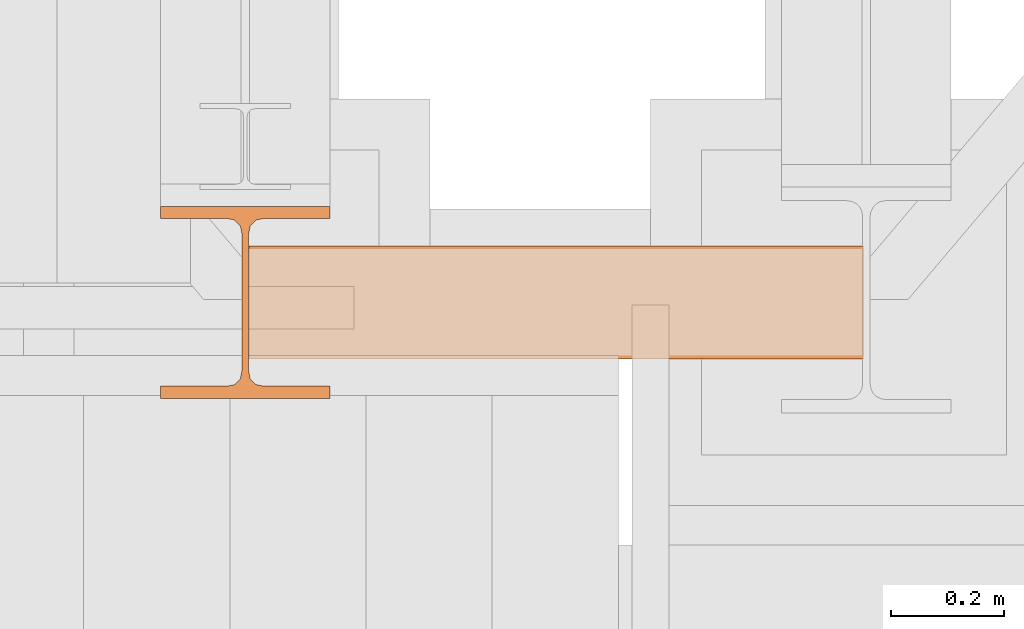
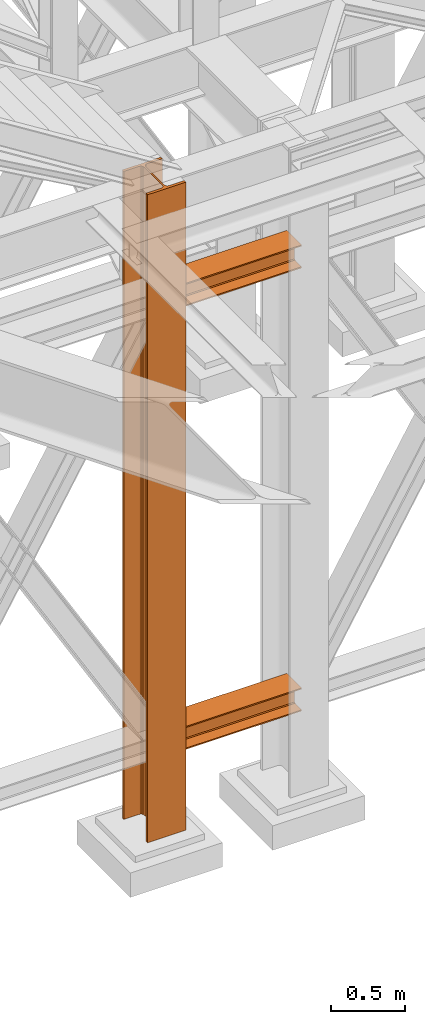
# One storey, part 22 of 208: 3 proxies.
"""IFC2X3 building model written with IfcOpenShell, lengths in millimetres."""

from ifc_helpers import new_model, entity, si_unit, converted_unit, frame, origin, origin_with_axes, place, context, subcontext, project, spatial, faceted_brep, material, element, save


model = new_model("IFC2X3")

# Units and contexts
model_context = context("Model", 3, precision=1e-05, world=origin())
plan_context = context("Plan", 3, precision=1e-05, world=origin())
body_context = subcontext(model_context, "Body", "Model", "MODEL_VIEW")
ifc_project = project(units=[si_unit("LENGTHUNIT", "METRE", prefix="MILLI"), converted_unit("PLANEANGLEUNIT", "DEGREE", entity("IfcPlaneAngleMeasure", 0.0174532925199433), si_unit("PLANEANGLEUNIT", "RADIAN"), dimensions=[0, 0, 0, 0, 0, 0, 0]), si_unit("AREAUNIT", "SQUARE_METRE"), si_unit("VOLUMEUNIT", "CUBIC_METRE")], contexts=[model_context, plan_context])

# Building, storey
building_placement = place(None, origin())
building = spatial("IfcBuilding", under=ifc_project, at=building_placement, CompositionType="COMPLEX")
storey_placement = place(building_placement, origin_with_axes())
storey = spatial("IfcBuildingStorey", under=building, at=storey_placement, Name="Geschoss", CompositionType="ELEMENT")

# Proxies
ifc_material = material(Name="35/80cm")
proxy_1_placement = place(storey_placement, frame((-1256.745037431798, -17432.57439531565, -65.01000000000022), z_axis=(0.0, 0.0, 1.0), x_axis=(1.0, 0.0, 0.0)))
element("IfcBuildingElementProxy", 1, at=proxy_1_placement, inside=storey, material=ifc_material, context=body_context, shape_type="Brep", body=[
    faceted_brep([(300.010011920929, 0.00999999999839929, 0.01000000000027512), (300.010011920929, 21.51000631809075, 0.01000000000027512), (183.0100057816505, 21.51000631809075, 0.01000000000027512), (169.0362909978628, 24.30682016372521, 0.01000000000027512), (158.8068282401562, 34.5362885093673, 0.01000000000027512), (156.0100060126185, 48.51000143050987, 0.01000000000027512), (156.0100060126185, 291.509994695185, 0.01000000000027512), (158.8068282401562, 305.4837150669082, 0.01000000000027512), (169.0362909978628, 315.7131685113891, 0.01000000000027512), (183.0100057816505, 318.5099972581847, 0.01000000000027512), (300.010011920929, 318.5099972581847, 0.01000000000027512), (300.010011920929, 340.0100035762771, 0.01000000000027512), (0.009999999999990905, 340.0100035762771, 0.01000000000027512), (0.009999999999990905, 318.5099972581847, 0.01000000000027512), (117.0100061392784, 318.5099972581847, 0.01000000000027512), (130.9837209230661, 315.7131685113891, 0.01000000000027512), (141.2131836807728, 305.4837150669082, 0.01000000000027512), (144.0100059083104, 291.509994695185, 0.01000000000027512), (144.0100059083104, 48.51000143050987, 0.01000000000027512), (141.2131836807728, 34.5362885093673, 0.01000000000027512), (130.9837209230661, 24.30682016372521, 0.01000000000027512), (117.0100061392784, 21.51000631809075, 0.01000000000027512), (0.009999999999990905, 21.51000631809075, 0.01000000000027512), (0.009999999999990905, 0.00999999999839929, 0.01000000000027512), (300.010011920929, 21.51000631809075, 5350.010005364416), (300.010011920929, 0.00999999999839929, 5350.010005364416), (0.009999999999990905, 0.00999999999839929, 5350.010005364416), (0.009999999999990905, 21.51000631809075, 5350.010005364416), (117.0100061392784, 21.51000631809075, 5350.010005364416), (130.9837209230661, 24.30682016372521, 5350.010005364416), (141.2131836807728, 34.5362885093673, 5350.010005364416), (144.0100059083104, 48.51000143050987, 5350.010005364416), (144.0100059083104, 291.509994695185, 5350.010005364416), (141.2131836807728, 305.4837150669082, 5350.010005364416), (130.9837209230661, 315.7131685113891, 5350.010005364416), (117.0100061392784, 318.5099972581847, 5350.010005364416), (0.009999999999990905, 318.5099972581847, 5350.010005364416), (0.009999999999990905, 340.0100035762771, 5350.010005364416), (300.010011920929, 340.0100035762771, 5350.010005364416), (300.010011920929, 318.5099972581847, 5350.010005364416), (183.0100057816505, 318.5099972581847, 5350.010005364416), (169.0362909978628, 315.7131685113891, 5350.010005364416), (158.8068282401562, 305.4837150669082, 5350.010005364416), (156.0100060126185, 291.509994695185, 5350.010005364416), (156.0100060126185, 48.51000143050987, 5350.010005364416), (158.8068282401562, 34.5362885093673, 5350.010005364416), (169.0362909978628, 24.30682016372521, 5350.010005364416), (183.0100057816505, 21.51000631809075, 5350.010005364416), (300.010011920929, 21.51000631809075, 0.01000000000027512), (300.010011920929, 0.00999999999839929, 0.01000000000027512), (300.010011920929, 0.00999999999839929, 5350.010005364416), (300.010011920929, 21.51000631809075, 5350.010005364416), (183.0100057816505, 21.51000631809075, 0.01000000000027512), (300.010011920929, 21.51000631809075, 0.01000000000027512), (300.010011920929, 21.51000631809075, 5350.010005364416), (183.0100057816505, 21.51000631809075, 5350.010005364416), (169.0362909978628, 24.30682016372521, 0.01000000000027512), (183.0100057816505, 21.51000631809075, 0.01000000000027512), (183.0100057816505, 21.51000631809075, 5350.010005364416), (169.0362909978628, 24.30682016372521, 5350.010005364416), (158.8068282401562, 34.5362885093673, 0.01000000000027512), (169.0362909978628, 24.30682016372521, 0.01000000000027512), (169.0362909978628, 24.30682016372521, 5350.010005364416), (158.8068282401562, 34.5362885093673, 5350.010005364416), (156.0100060126185, 48.51000143050987, 0.01000000000027512), (158.8068282401562, 34.5362885093673, 0.01000000000027512), (158.8068282401562, 34.5362885093673, 5350.010005364416), (156.0100060126185, 48.51000143050987, 5350.010005364416), (156.0100060126185, 291.509994695185, 0.01000000000027512), (156.0100060126185, 48.51000143050987, 0.01000000000027512), (156.0100060126185, 48.51000143050987, 5350.010005364416), (156.0100060126185, 291.509994695185, 5350.010005364416), (158.8068282401562, 305.4837150669082, 0.01000000000027512), (156.0100060126185, 291.509994695185, 0.01000000000027512), (156.0100060126185, 291.509994695185, 5350.010005364416), (158.8068282401562, 305.4837150669082, 5350.010005364416), (169.0362909978628, 315.7131685113891, 0.01000000000027512), (158.8068282401562, 305.4837150669082, 0.01000000000027512), (158.8068282401562, 305.4837150669082, 5350.010005364416), (169.0362909978628, 315.7131685113891, 5350.010005364416), (183.0100057816505, 318.5099972581847, 0.01000000000027512), (169.0362909978628, 315.7131685113891, 0.01000000000027512), (169.0362909978628, 315.7131685113891, 5350.010005364416), (183.0100057816505, 318.5099972581847, 5350.010005364416), (300.010011920929, 318.5099972581847, 0.01000000000027512), (183.0100057816505, 318.5099972581847, 0.01000000000027512), (183.0100057816505, 318.5099972581847, 5350.010005364416), (300.010011920929, 318.5099972581847, 5350.010005364416), (300.010011920929, 340.0100035762771, 0.01000000000027512), (300.010011920929, 318.5099972581847, 0.01000000000027512), (300.010011920929, 318.5099972581847, 5350.010005364416), (300.010011920929, 340.0100035762771, 5350.010005364416), (0.009999999999990905, 340.0100035762771, 0.01000000000027512), (300.010011920929, 340.0100035762771, 0.01000000000027512), (300.010011920929, 340.0100035762771, 5350.010005364416), (0.009999999999990905, 340.0100035762771, 5350.010005364416), (0.009999999999990905, 318.5099972581847, 0.01000000000027512), (0.009999999999990905, 340.0100035762771, 0.01000000000027512), (0.009999999999990905, 340.0100035762771, 5350.010005364416), (0.009999999999990905, 318.5099972581847, 5350.010005364416), (117.0100061392784, 318.5099972581847, 0.01000000000027512), (0.009999999999990905, 318.5099972581847, 0.01000000000027512), (0.009999999999990905, 318.5099972581847, 5350.010005364416), (117.0100061392784, 318.5099972581847, 5350.010005364416), (130.9837209230661, 315.7131685113891, 0.01000000000027512), (117.0100061392784, 318.5099972581847, 0.01000000000027512), (117.0100061392784, 318.5099972581847, 5350.010005364416), (130.9837209230661, 315.7131685113891, 5350.010005364416), (141.2131836807728, 305.4837150669082, 0.01000000000027512), (130.9837209230661, 315.7131685113891, 0.01000000000027512), (130.9837209230661, 315.7131685113891, 5350.010005364416), (141.2131836807728, 305.4837150669082, 5350.010005364416), (144.0100059083104, 291.509994695185, 0.01000000000027512), (141.2131836807728, 305.4837150669082, 0.01000000000027512), (141.2131836807728, 305.4837150669082, 5350.010005364416), (144.0100059083104, 291.509994695185, 5350.010005364416), (144.0100059083104, 48.51000143050987, 0.01000000000027512), (144.0100059083104, 291.509994695185, 0.01000000000027512), (144.0100059083104, 291.509994695185, 5350.010005364416), (144.0100059083104, 48.51000143050987, 5350.010005364416), (141.2131836807728, 34.5362885093673, 0.01000000000027512), (144.0100059083104, 48.51000143050987, 0.01000000000027512), (144.0100059083104, 48.51000143050987, 5350.010005364416), (141.2131836807728, 34.5362885093673, 5350.010005364416), (130.9837209230661, 24.30682016372521, 0.01000000000027512), (141.2131836807728, 34.5362885093673, 0.01000000000027512), (141.2131836807728, 34.5362885093673, 5350.010005364416), (130.9837209230661, 24.30682016372521, 5350.010005364416), (117.0100061392784, 21.51000631809075, 0.01000000000027512), (130.9837209230661, 24.30682016372521, 0.01000000000027512), (130.9837209230661, 24.30682016372521, 5350.010005364416), (117.0100061392784, 21.51000631809075, 5350.010005364416), (0.009999999999990905, 21.51000631809075, 0.01000000000027512), (117.0100061392784, 21.51000631809075, 0.01000000000027512), (117.0100061392784, 21.51000631809075, 5350.010005364416), (0.009999999999990905, 21.51000631809075, 5350.010005364416), (0.009999999999990905, 0.00999999999839929, 0.01000000000027512), (0.009999999999990905, 21.51000631809075, 0.01000000000027512), (0.009999999999990905, 21.51000631809075, 5350.010005364416), (0.009999999999990905, 0.00999999999839929, 5350.010005364416), (300.010011920929, 0.00999999999839929, 0.01000000000027512), (0.009999999999990905, 0.00999999999839929, 0.01000000000027512), (0.009999999999990905, 0.00999999999839929, 5350.010005364416), (300.010011920929, 0.00999999999839929, 5350.010005364416)], [[[0, 1, 2, 3, 4, 5, 6, 7, 8, 9, 10, 11, 12, 13, 14, 15, 16, 17, 18, 19, 20, 21, 22, 23]], [[24, 25, 26, 27, 28, 29, 30, 31, 32, 33, 34, 35, 36, 37, 38, 39, 40, 41, 42, 43, 44, 45, 46, 47]], [[48, 49, 50, 51]], [[52, 53, 54, 55]], [[56, 57, 58, 59]], [[60, 61, 62, 63]], [[64, 65, 66, 67]], [[68, 69, 70, 71]], [[72, 73, 74, 75]], [[76, 77, 78, 79]], [[80, 81, 82, 83]], [[84, 85, 86, 87]], [[88, 89, 90, 91]], [[92, 93, 94, 95]], [[96, 97, 98, 99]], [[100, 101, 102, 103]], [[104, 105, 106, 107]], [[108, 109, 110, 111]], [[112, 113, 114, 115]], [[116, 117, 118, 119]], [[120, 121, 122, 123]], [[124, 125, 126, 127]], [[128, 129, 130, 131]], [[132, 133, 134, 135]], [[136, 137, 138, 139]], [[140, 141, 142, 143]]], orient=[[False], [False], [False], [False], [False], [False], [False], [False], [False], [False], [False], [False], [False], [False], [False], [False], [False], [False], [False], [False], [False], [False], [False], [False], [False], [False]]),
])
proxy_2_placement = place(storey_placement, frame((-1099.995025406557, -17362.5323246858, 544.9900024165573), z_axis=(0.0, 0.0, 1.0), x_axis=(1.0, 0.0, 0.0)))
element("IfcBuildingElementProxy", 2, at=proxy_2_placement, inside=storey, context=body_context, shape_type="Brep", body=[
    faceted_brep([(1088.009999895692, 0.00999999999839929, 190.0100125169756), (1088.009999895692, 200.0100029802306, 190.0100125169756), (1088.009999895692, 200.0100029802306, 180.0100146031382), (1088.009999895692, 121.2600035762771, 180.0100071525576), (1088.009999895692, 111.9441915473326, 178.1454621052744), (1088.009999895692, 105.1245498640819, 171.3258190250399), (1088.009999895692, 103.2600015571697, 162.010007927418), (1088.009999895692, 103.2600015571697, 28.00999713897727), (1088.009999895692, 105.1245498640819, 18.69418604135535), (1088.009999895692, 111.9441915473326, 11.87454296112082), (1088.009999895692, 121.2600035762771, 10.00999791383765), (1088.009999895692, 200.0100029802306, 10.00999791383765), (1088.009999895692, 200.0100029802306, 0.01000000000021828), (1088.009999895692, 0.00999999999839929, 0.01000000000021828), (1088.009999895692, 0.00999999999839929, 10.00999791383765), (1088.009999895692, 78.75999940395195, 10.00999791383765), (1088.009999895692, 88.07581143289644, 11.87454296112082), (1088.009999895692, 94.89545311614711, 18.69418604135535), (1088.009999895692, 96.7600014230593, 28.00999713897727), (1088.009999895692, 96.7600014230593, 162.010007927418), (1088.009999895692, 94.89545311614711, 171.3258190250399), (1088.009999895692, 88.07581143289644, 178.1454621052744), (1088.009999895692, 78.75999940395195, 180.0100071525576), (1088.009999895692, 0.00999999999839929, 180.0100146031382), (1088.009999895692, 200.0100029802306, 190.0100125169756), (1088.009999895692, 0.00999999999839929, 190.0100125169756), (0.009999999999990905, 0.00999999999839929, 190.0100125169755), (0.009999999999990905, 200.0100029802306, 190.0100125169755), (1088.009999895692, 200.0100029802306, 180.0100146031382), (1088.009999895692, 200.0100029802306, 190.0100125169756), (0.009999999999990905, 200.0100029802306, 190.0100125169755), (0.009999999999990905, 200.0100029802306, 180.0100146031381), (1088.009999895692, 121.2600035762771, 180.0100071525576), (1088.009999895692, 200.0100029802306, 180.0100146031382), (0.009999999999990905, 200.0100029802306, 180.0100146031381), (0.009999999999990905, 121.2600035762771, 180.0100071525575), (1088.009999895692, 111.9441915473326, 178.1454621052744), (1088.009999895692, 121.2600035762771, 180.0100071525576), (0.009999999999990905, 121.2600035762771, 180.0100071525575), (0.009999999999990905, 111.9441915473326, 178.1454621052743), (1088.009999895692, 105.1245498640819, 171.3258190250399), (1088.009999895692, 111.9441915473326, 178.1454621052744), (0.009999999999990905, 111.9441915473326, 178.1454621052743), (0.009999999999990905, 105.1245498640819, 171.3258190250398), (1088.009999895692, 103.2600015571697, 162.010007927418), (1088.009999895692, 105.1245498640819, 171.3258190250399), (0.009999999999990905, 105.1245498640819, 171.3258190250398), (0.009999999999990905, 103.2600015571697, 162.0100079274179), (1088.009999895692, 103.2600015571697, 28.00999713897727), (1088.009999895692, 103.2600015571697, 162.010007927418), (0.009999999999990905, 103.2600015571697, 162.0100079274179), (0.009999999999990905, 103.2600015571697, 28.00999713897716), (1088.009999895692, 105.1245498640819, 18.69418604135535), (1088.009999895692, 103.2600015571697, 28.00999713897727), (0.009999999999990905, 103.2600015571697, 28.00999713897716), (0.009999999999990905, 105.1245498640819, 18.69418604135524), (1088.009999895692, 111.9441915473326, 11.87454296112082), (1088.009999895692, 105.1245498640819, 18.69418604135535), (0.009999999999990905, 105.1245498640819, 18.69418604135524), (0.009999999999990905, 111.9441915473326, 11.87454296112071), (1088.009999895692, 121.2600035762771, 10.00999791383765), (1088.009999895692, 111.9441915473326, 11.87454296112082), (0.009999999999990905, 111.9441915473326, 11.87454296112071), (0.009999999999990905, 121.2600035762771, 10.00999791383754), (1088.009999895692, 200.0100029802306, 10.00999791383765), (1088.009999895692, 121.2600035762771, 10.00999791383765), (0.009999999999990905, 121.2600035762771, 10.00999791383754), (0.009999999999990905, 200.0100029802306, 10.00999791383754), (1088.009999895692, 200.0100029802306, 0.01000000000021828), (1088.009999895692, 200.0100029802306, 10.00999791383765), (0.009999999999990905, 200.0100029802306, 10.00999791383754), (0.009999999999990905, 200.0100029802306, 0.01000000000010459), (1088.009999895692, 0.00999999999839929, 0.01000000000021828), (1088.009999895692, 200.0100029802306, 0.01000000000021828), (0.009999999999990905, 200.0100029802306, 0.01000000000010459), (0.009999999999990905, 0.00999999999839929, 0.01000000000010459), (1088.009999895692, 0.00999999999839929, 10.00999791383765), (1088.009999895692, 0.00999999999839929, 0.01000000000021828), (0.009999999999990905, 0.00999999999839929, 0.01000000000010459), (0.009999999999990905, 0.00999999999839929, 10.00999791383754), (1088.009999895692, 78.75999940395195, 10.00999791383765), (1088.009999895692, 0.00999999999839929, 10.00999791383765), (0.009999999999990905, 0.00999999999839929, 10.00999791383754), (0.009999999999990905, 78.75999940395195, 10.00999791383754), (1088.009999895692, 88.07581143289644, 11.87454296112082), (1088.009999895692, 78.75999940395195, 10.00999791383765), (0.009999999999990905, 78.75999940395195, 10.00999791383754), (0.009999999999990905, 88.07581143289644, 11.87454296112071), (1088.009999895692, 94.89545311614711, 18.69418604135535), (1088.009999895692, 88.07581143289644, 11.87454296112082), (0.009999999999990905, 88.07581143289644, 11.87454296112071), (0.009999999999990905, 94.89545311614711, 18.69418604135524), (1088.009999895692, 96.7600014230593, 28.00999713897727), (1088.009999895692, 94.89545311614711, 18.69418604135535), (0.009999999999990905, 94.89545311614711, 18.69418604135524), (0.009999999999990905, 96.7600014230593, 28.00999713897716), (1088.009999895692, 96.7600014230593, 162.010007927418), (1088.009999895692, 96.7600014230593, 28.00999713897727), (0.009999999999990905, 96.7600014230593, 28.00999713897716), (0.009999999999990905, 96.7600014230593, 162.0100079274179), (1088.009999895692, 94.89545311614711, 171.3258190250399), (1088.009999895692, 96.7600014230593, 162.010007927418), (0.009999999999990905, 96.7600014230593, 162.0100079274179), (0.009999999999990905, 94.89545311614711, 171.3258190250398), (1088.009999895692, 88.07581143289644, 178.1454621052744), (1088.009999895692, 94.89545311614711, 171.3258190250399), (0.009999999999990905, 94.89545311614711, 171.3258190250398), (0.009999999999990905, 88.07581143289644, 178.1454621052743), (1088.009999895692, 78.75999940395195, 180.0100071525576), (1088.009999895692, 88.07581143289644, 178.1454621052744), (0.009999999999990905, 88.07581143289644, 178.1454621052743), (0.009999999999990905, 78.75999940395195, 180.0100071525575), (1088.009999895692, 0.00999999999839929, 180.0100146031382), (1088.009999895692, 78.75999940395195, 180.0100071525576), (0.009999999999990905, 78.75999940395195, 180.0100071525575), (0.009999999999990905, 0.00999999999839929, 180.0100146031381), (1088.009999895692, 0.00999999999839929, 190.0100125169756), (1088.009999895692, 0.00999999999839929, 180.0100146031382), (0.009999999999990905, 0.00999999999839929, 180.0100146031381), (0.009999999999990905, 0.00999999999839929, 190.0100125169755), (0.009999999999990905, 0.00999999999839929, 190.0100125169755), (0.009999999999990905, 0.00999999999839929, 180.0100146031381), (0.009999999999990905, 78.75999940395195, 180.0100071525575), (0.009999999999990905, 88.07581143289644, 178.1454621052743), (0.009999999999990905, 94.89545311614711, 171.3258190250398), (0.009999999999990905, 96.7600014230593, 162.0100079274179), (0.009999999999990905, 96.7600014230593, 28.00999713897716), (0.009999999999990905, 94.89545311614711, 18.69418604135524), (0.009999999999990905, 88.07581143289644, 11.87454296112071), (0.009999999999990905, 78.75999940395195, 10.00999791383754), (0.009999999999990905, 0.00999999999839929, 10.00999791383754), (0.009999999999990905, 0.00999999999839929, 0.01000000000010459), (0.009999999999990905, 200.0100029802306, 0.01000000000010459), (0.009999999999990905, 200.0100029802306, 10.00999791383754), (0.009999999999990905, 121.2600035762771, 10.00999791383754), (0.009999999999990905, 111.9441915473326, 11.87454296112071), (0.009999999999990905, 105.1245498640819, 18.69418604135524), (0.009999999999990905, 103.2600015571697, 28.00999713897716), (0.009999999999990905, 103.2600015571697, 162.0100079274179), (0.009999999999990905, 105.1245498640819, 171.3258190250398), (0.009999999999990905, 111.9441915473326, 178.1454621052743), (0.009999999999990905, 121.2600035762771, 180.0100071525575), (0.009999999999990905, 200.0100029802306, 180.0100146031381), (0.009999999999990905, 200.0100029802306, 190.0100125169755)], [[[0, 1, 2, 3, 4, 5, 6, 7, 8, 9, 10, 11, 12, 13, 14, 15, 16, 17, 18, 19, 20, 21, 22, 23]], [[24, 25, 26, 27]], [[28, 29, 30, 31]], [[32, 33, 34, 35]], [[36, 37, 38, 39]], [[40, 41, 42, 43]], [[44, 45, 46, 47]], [[48, 49, 50, 51]], [[52, 53, 54, 55]], [[56, 57, 58, 59]], [[60, 61, 62, 63]], [[64, 65, 66, 67]], [[68, 69, 70, 71]], [[72, 73, 74, 75]], [[76, 77, 78, 79]], [[80, 81, 82, 83]], [[84, 85, 86, 87]], [[88, 89, 90, 91]], [[92, 93, 94, 95]], [[96, 97, 98, 99]], [[100, 101, 102, 103]], [[104, 105, 106, 107]], [[108, 109, 110, 111]], [[112, 113, 114, 115]], [[116, 117, 118, 119]], [[120, 121, 122, 123, 124, 125, 126, 127, 128, 129, 130, 131, 132, 133, 134, 135, 136, 137, 138, 139, 140, 141, 142, 143]]], orient=[[False], [False], [False], [False], [False], [False], [False], [False], [False], [False], [False], [False], [False], [False], [False], [False], [False], [False], [False], [False], [False], [False], [False], [False], [False], [False]]),
])
proxy_3_placement = place(storey_placement, frame((-1099.995025406557, -17362.5323246858, 4202.989992847441), z_axis=(0.0, 0.0, 1.0), x_axis=(1.0, 0.0, 0.0)))
element("IfcBuildingElementProxy", 3, at=proxy_3_placement, inside=storey, context=body_context, shape_type="Brep", body=[
    faceted_brep([(1088.009999895692, 0.00999999999839929, 190.0100125169756), (1088.009999895692, 200.0100029802306, 190.0100125169756), (1088.009999895692, 200.0100029802306, 180.0100146031382), (1088.009999895692, 121.2600035762771, 180.0100071525576), (1088.009999895692, 111.9441915473326, 178.1454621052744), (1088.009999895692, 105.1245498640819, 171.3258190250399), (1088.009999895692, 103.2600015571697, 162.010007927418), (1088.009999895692, 103.2600015571697, 28.00999713897727), (1088.009999895692, 105.1245498640819, 18.69418604135535), (1088.009999895692, 111.9441915473326, 11.87454296112082), (1088.009999895692, 121.2600035762771, 10.00999791383765), (1088.009999895692, 200.0100029802306, 10.00999791383765), (1088.009999895692, 200.0100029802306, 0.01000000000021828), (1088.009999895692, 0.00999999999839929, 0.01000000000021828), (1088.009999895692, 0.00999999999839929, 10.00999791383765), (1088.009999895692, 78.75999940395195, 10.00999791383765), (1088.009999895692, 88.07581143289644, 11.87454296112082), (1088.009999895692, 94.89545311614711, 18.69418604135535), (1088.009999895692, 96.7600014230593, 28.00999713897727), (1088.009999895692, 96.7600014230593, 162.010007927418), (1088.009999895692, 94.89545311614711, 171.3258190250399), (1088.009999895692, 88.07581143289644, 178.1454621052744), (1088.009999895692, 78.75999940395195, 180.0100071525576), (1088.009999895692, 0.00999999999839929, 180.0100146031382), (1088.009999895692, 200.0100029802306, 190.0100125169756), (1088.009999895692, 0.00999999999839929, 190.0100125169756), (0.009999999999990905, 0.00999999999839929, 190.0100125169756), (0.009999999999990905, 200.0100029802306, 190.0100125169756), (1088.009999895692, 200.0100029802306, 180.0100146031382), (1088.009999895692, 200.0100029802306, 190.0100125169756), (0.009999999999990905, 200.0100029802306, 190.0100125169756), (0.009999999999990905, 200.0100029802306, 180.0100146031382), (1088.009999895692, 121.2600035762771, 180.0100071525576), (1088.009999895692, 200.0100029802306, 180.0100146031382), (0.009999999999990905, 200.0100029802306, 180.0100146031382), (0.009999999999990905, 121.2600035762771, 180.0100071525576), (1088.009999895692, 111.9441915473326, 178.1454621052744), (1088.009999895692, 121.2600035762771, 180.0100071525576), (0.009999999999990905, 121.2600035762771, 180.0100071525576), (0.009999999999990905, 111.9441915473326, 178.1454621052744), (1088.009999895692, 105.1245498640819, 171.3258190250399), (1088.009999895692, 111.9441915473326, 178.1454621052744), (0.009999999999990905, 111.9441915473326, 178.1454621052744), (0.009999999999990905, 105.1245498640819, 171.3258190250399), (1088.009999895692, 103.2600015571697, 162.010007927418), (1088.009999895692, 105.1245498640819, 171.3258190250399), (0.009999999999990905, 105.1245498640819, 171.3258190250399), (0.009999999999990905, 103.2600015571697, 162.010007927418), (1088.009999895692, 103.2600015571697, 28.00999713897727), (1088.009999895692, 103.2600015571697, 162.010007927418), (0.009999999999990905, 103.2600015571697, 162.010007927418), (0.009999999999990905, 103.2600015571697, 28.00999713897727), (1088.009999895692, 105.1245498640819, 18.69418604135535), (1088.009999895692, 103.2600015571697, 28.00999713897727), (0.009999999999990905, 103.2600015571697, 28.00999713897727), (0.009999999999990905, 105.1245498640819, 18.69418604135535), (1088.009999895692, 111.9441915473326, 11.87454296112082), (1088.009999895692, 105.1245498640819, 18.69418604135535), (0.009999999999990905, 105.1245498640819, 18.69418604135535), (0.009999999999990905, 111.9441915473326, 11.87454296112082), (1088.009999895692, 121.2600035762771, 10.00999791383765), (1088.009999895692, 111.9441915473326, 11.87454296112082), (0.009999999999990905, 111.9441915473326, 11.87454296112082), (0.009999999999990905, 121.2600035762771, 10.00999791383765), (1088.009999895692, 200.0100029802306, 10.00999791383765), (1088.009999895692, 121.2600035762771, 10.00999791383765), (0.009999999999990905, 121.2600035762771, 10.00999791383765), (0.009999999999990905, 200.0100029802306, 10.00999791383765), (1088.009999895692, 200.0100029802306, 0.01000000000021828), (1088.009999895692, 200.0100029802306, 10.00999791383765), (0.009999999999990905, 200.0100029802306, 10.00999791383765), (0.009999999999990905, 200.0100029802306, 0.01000000000021828), (1088.009999895692, 0.00999999999839929, 0.01000000000021828), (1088.009999895692, 200.0100029802306, 0.01000000000021828), (0.009999999999990905, 200.0100029802306, 0.01000000000021828), (0.009999999999990905, 0.00999999999839929, 0.01000000000021828), (1088.009999895692, 0.00999999999839929, 10.00999791383765), (1088.009999895692, 0.00999999999839929, 0.01000000000021828), (0.009999999999990905, 0.00999999999839929, 0.01000000000021828), (0.009999999999990905, 0.00999999999839929, 10.00999791383765), (1088.009999895692, 78.75999940395195, 10.00999791383765), (1088.009999895692, 0.00999999999839929, 10.00999791383765), (0.009999999999990905, 0.00999999999839929, 10.00999791383765), (0.009999999999990905, 78.75999940395195, 10.00999791383765), (1088.009999895692, 88.07581143289644, 11.87454296112082), (1088.009999895692, 78.75999940395195, 10.00999791383765), (0.009999999999990905, 78.75999940395195, 10.00999791383765), (0.009999999999990905, 88.07581143289644, 11.87454296112082), (1088.009999895692, 94.89545311614711, 18.69418604135535), (1088.009999895692, 88.07581143289644, 11.87454296112082), (0.009999999999990905, 88.07581143289644, 11.87454296112082), (0.009999999999990905, 94.89545311614711, 18.69418604135535), (1088.009999895692, 96.7600014230593, 28.00999713897727), (1088.009999895692, 94.89545311614711, 18.69418604135535), (0.009999999999990905, 94.89545311614711, 18.69418604135535), (0.009999999999990905, 96.7600014230593, 28.00999713897727), (1088.009999895692, 96.7600014230593, 162.010007927418), (1088.009999895692, 96.7600014230593, 28.00999713897727), (0.009999999999990905, 96.7600014230593, 28.00999713897727), (0.009999999999990905, 96.7600014230593, 162.010007927418), (1088.009999895692, 94.89545311614711, 171.3258190250399), (1088.009999895692, 96.7600014230593, 162.010007927418), (0.009999999999990905, 96.7600014230593, 162.010007927418), (0.009999999999990905, 94.89545311614711, 171.3258190250399), (1088.009999895692, 88.07581143289644, 178.1454621052744), (1088.009999895692, 94.89545311614711, 171.3258190250399), (0.009999999999990905, 94.89545311614711, 171.3258190250399), (0.009999999999990905, 88.07581143289644, 178.1454621052744), (1088.009999895692, 78.75999940395195, 180.0100071525576), (1088.009999895692, 88.07581143289644, 178.1454621052744), (0.009999999999990905, 88.07581143289644, 178.1454621052744), (0.009999999999990905, 78.75999940395195, 180.0100071525576), (1088.009999895692, 0.00999999999839929, 180.0100146031382), (1088.009999895692, 78.75999940395195, 180.0100071525576), (0.009999999999990905, 78.75999940395195, 180.0100071525576), (0.009999999999990905, 0.00999999999839929, 180.0100146031382), (1088.009999895692, 0.00999999999839929, 190.0100125169756), (1088.009999895692, 0.00999999999839929, 180.0100146031382), (0.009999999999990905, 0.00999999999839929, 180.0100146031382), (0.009999999999990905, 0.00999999999839929, 190.0100125169756), (0.009999999999990905, 0.00999999999839929, 190.0100125169756), (0.009999999999990905, 0.00999999999839929, 180.0100146031382), (0.009999999999990905, 78.75999940395195, 180.0100071525576), (0.009999999999990905, 88.07581143289644, 178.1454621052744), (0.009999999999990905, 94.89545311614711, 171.3258190250399), (0.009999999999990905, 96.7600014230593, 162.010007927418), (0.009999999999990905, 96.7600014230593, 28.00999713897727), (0.009999999999990905, 94.89545311614711, 18.69418604135535), (0.009999999999990905, 88.07581143289644, 11.87454296112082), (0.009999999999990905, 78.75999940395195, 10.00999791383765), (0.009999999999990905, 0.00999999999839929, 10.00999791383765), (0.009999999999990905, 0.00999999999839929, 0.01000000000021828), (0.009999999999990905, 200.0100029802306, 0.01000000000021828), (0.009999999999990905, 200.0100029802306, 10.00999791383765), (0.009999999999990905, 121.2600035762771, 10.00999791383765), (0.009999999999990905, 111.9441915473326, 11.87454296112082), (0.009999999999990905, 105.1245498640819, 18.69418604135535), (0.009999999999990905, 103.2600015571697, 28.00999713897727), (0.009999999999990905, 103.2600015571697, 162.010007927418), (0.009999999999990905, 105.1245498640819, 171.3258190250399), (0.009999999999990905, 111.9441915473326, 178.1454621052744), (0.009999999999990905, 121.2600035762771, 180.0100071525576), (0.009999999999990905, 200.0100029802306, 180.0100146031382), (0.009999999999990905, 200.0100029802306, 190.0100125169756)], [[[0, 1, 2, 3, 4, 5, 6, 7, 8, 9, 10, 11, 12, 13, 14, 15, 16, 17, 18, 19, 20, 21, 22, 23]], [[24, 25, 26, 27]], [[28, 29, 30, 31]], [[32, 33, 34, 35]], [[36, 37, 38, 39]], [[40, 41, 42, 43]], [[44, 45, 46, 47]], [[48, 49, 50, 51]], [[52, 53, 54, 55]], [[56, 57, 58, 59]], [[60, 61, 62, 63]], [[64, 65, 66, 67]], [[68, 69, 70, 71]], [[72, 73, 74, 75]], [[76, 77, 78, 79]], [[80, 81, 82, 83]], [[84, 85, 86, 87]], [[88, 89, 90, 91]], [[92, 93, 94, 95]], [[96, 97, 98, 99]], [[100, 101, 102, 103]], [[104, 105, 106, 107]], [[108, 109, 110, 111]], [[112, 113, 114, 115]], [[116, 117, 118, 119]], [[120, 121, 122, 123, 124, 125, 126, 127, 128, 129, 130, 131, 132, 133, 134, 135, 136, 137, 138, 139, 140, 141, 142, 143]]], orient=[[False], [False], [False], [False], [False], [False], [False], [False], [False], [False], [False], [False], [False], [False], [False], [False], [False], [False], [False], [False], [False], [False], [False], [False], [False], [False]]),
])

save(model, "model.ifc")
